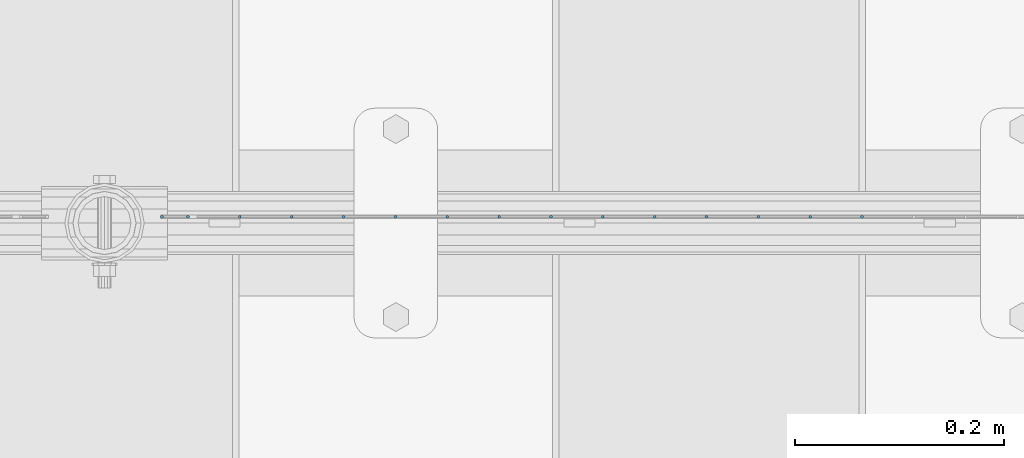
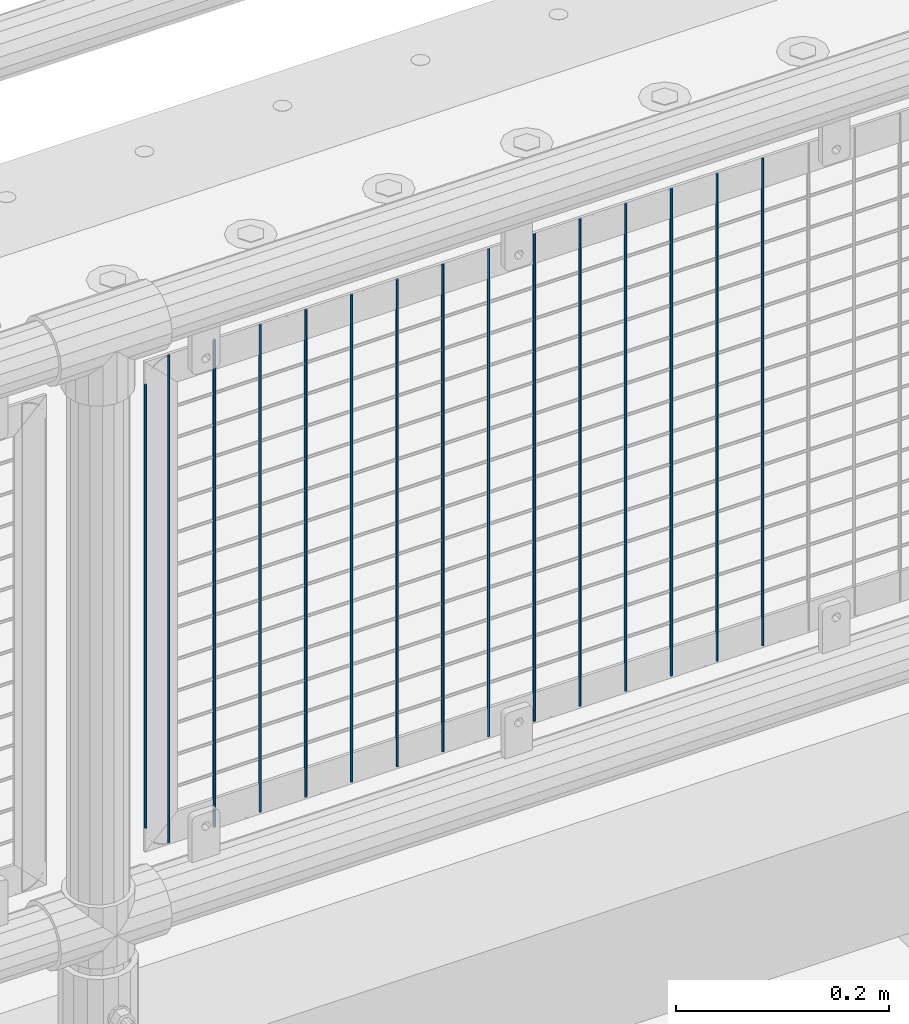
# One storey, part 69 of 257: 15 columns.
"""IFC2X3 building model written with IfcOpenShell, lengths in millimetres."""

import ifcopenshell
import ifcopenshell.guid

model = None  # the IFC model being written
_history = None  # IfcOwnerHistory: only IFC2X3 demands one
_inside = {}  # id of a spatial element -> (the spatial element, [elements in it])
_under = {}  # id of a project, library or spatial element -> (it, [spatial elements below it])
_declared = {}  # id of a project -> (the project, [libraries it declares])
_typed = {}  # id of a type object -> (the type object, [elements of that type])
_made_of = {}  # id of a material, layer set ... -> (it, [elements and type objects made of it])


def new_model(schema):
    """Start an empty IFC model of exactly this schema.

    Asked for "IFC4X3", IfcOpenShell would pick the latest addendum, in which some entities
    have other attributes; the version numbers below select the first issue.
    IFC2X3 requires an IfcOwnerHistory on every rooted entity: one is made here for all.
    """
    global model, _history
    if schema == "IFC4X3":
        model = ifcopenshell.file(schema_version=(4, 3, 0, 0))
    else:
        model = ifcopenshell.file(schema=schema)
    _inside.clear()
    _under.clear()
    _declared.clear()
    _typed.clear()
    _made_of.clear()
    _history = None
    if model.schema == "IFC2X3":
        org = make("IfcOrganization", Name="unknown")
        user = make(
            "IfcPersonAndOrganization",
            ThePerson=make("IfcPerson", FamilyName="unknown"),
            TheOrganization=org,
        )
        app = make(
            "IfcApplication",
            ApplicationDeveloper=org,
            Version="unknown",
            ApplicationFullName="unknown",
            ApplicationIdentifier="unknown",
        )
        _history = make(
            "IfcOwnerHistory",
            OwningUser=user,
            OwningApplication=app,
            ChangeAction="ADDED",
            CreationDate=0,
        )
    return model


def make(cls, **values):
    """One entity of the class cls with the attributes given. An attribute that is None is left unset."""
    return model.create_entity(
        cls, **{name: value for name, value in values.items() if value is not None}
    )


def rooted(cls, **values):
    """An entity with a GlobalId (a new one), such as an element, a storey or a relation."""
    return make(cls, GlobalId=ifcopenshell.guid.new(), OwnerHistory=_history, **values)


def si_unit(unit_type, name, prefix=None):
    """IfcSIUnit, for example si_unit("LENGTHUNIT", "METRE", prefix="MILLI")."""
    return make("IfcSIUnit", UnitType=unit_type, Prefix=prefix, Name=name)


def assignment(units):
    """IfcUnitAssignment: the units of a project."""
    return None if units is None else make("IfcUnitAssignment", Units=units)


def point(xyz):
    """IfcCartesianPoint."""
    return None if xyz is None else make("IfcCartesianPoint", Coordinates=xyz)


def direction(xyz):
    """IfcDirection."""
    return None if xyz is None else make("IfcDirection", DirectionRatios=xyz)


def frame(location, z_axis=None, x_axis=None):
    """IfcAxis2Placement3D, a coordinate frame: its origin and axes. An axis left out is left unset."""
    return make(
        "IfcAxis2Placement3D",
        Location=point(location),
        Axis=direction(z_axis),
        RefDirection=direction(x_axis),
    )


def origin_with_axes():
    """The frame at (0, 0, 0) with the z axis (0, 0, 1) and the x axis (1, 0, 0) written out."""
    return frame((0.0, 0.0, 0.0), z_axis=(0.0, 0.0, 1.0), x_axis=(1.0, 0.0, 0.0))


def place(relative_to, where):
    """IfcLocalPlacement: puts the frame where relative to a parent placement (None: the world)."""
    return make(
        "IfcLocalPlacement", PlacementRelTo=relative_to, RelativePlacement=where
    )


def context(
    kind, dimensions, precision=None, world=None, true_north=None, identifier=None
):
    """IfcGeometricRepresentationContext, for example the 3D "Model" context."""
    return make(
        "IfcGeometricRepresentationContext",
        ContextIdentifier=identifier,
        ContextType=kind,
        CoordinateSpaceDimension=dimensions,
        Precision=precision,
        WorldCoordinateSystem=world,
        TrueNorth=true_north,
    )


def subcontext(parent, identifier, kind, view, scale=None):
    """IfcGeometricRepresentationSubContext, for example "Body" below "Model"."""
    return make(
        "IfcGeometricRepresentationSubContext",
        ContextIdentifier=identifier,
        ContextType=kind,
        ParentContext=parent,
        TargetScale=scale,
        TargetView=view,
    )


def project(units=None, contexts=None):
    """IfcProject with its units and contexts."""
    return rooted(
        "IfcProject",
        Name="project",
        RepresentationContexts=contexts,
        UnitsInContext=assignment(units),
    )


def spatial(cls, under=None, at=None, **own):
    """A site, building, storey or space (cls), placed at a placement, below another one or the project."""
    s = rooted(cls, ObjectPlacement=at, **own)
    if under is not None:
        _under.setdefault(under.id(), (under, []))[1].append(s)
    return s


def faces_of(points, faces, orient=None, outer=None):
    """IfcFace entities. A face is a list of loops; a loop is a list of indices into points, from 0.

    orient and outer hold one flag for each loop. By default every Orientation is true, the
    first loop of a face is its IfcFaceOuterBound and the others are IfcFaceBound.
    """
    made = []
    for i, loops in enumerate(faces):
        bounds = []
        for j, loop in enumerate(loops):
            is_outer = j == 0 if outer is None else outer[i][j]
            bounds.append(
                make(
                    "IfcFaceOuterBound" if is_outer else "IfcFaceBound",
                    Bound=make("IfcPolyLoop", Polygon=[points[k] for k in loop]),
                    Orientation=True if orient is None else orient[i][j],
                )
            )
        made.append(make("IfcFace", Bounds=bounds))
    return made


def faceted_brep(points, faces, orient=None, outer=None, voids=None):
    """IfcFacetedBrep: a solid bounded by flat faces; with voids (closed shells), ...WithVoids."""
    shared = [point(p) for p in points]
    hull = make("IfcClosedShell", CfsFaces=faces_of(shared, faces, orient, outer))
    if voids is None:
        return make("IfcFacetedBrep", Outer=hull)
    return make(
        "IfcFacetedBrepWithVoids",
        Outer=hull,
        Voids=[
            make(cls, CfsFaces=faces_of(shared, fs, o, b)) for cls, fs, o, b in voids
        ],
    )


def shape(context_of_items, identifier, shape_type, items):
    """IfcShapeRepresentation: the items that make up one representation, for example the "Body"."""
    return make(
        "IfcShapeRepresentation",
        ContextOfItems=context_of_items,
        RepresentationIdentifier=identifier,
        RepresentationType=shape_type,
        Items=items,
    )


def material(Name=None, Category=None):
    """IfcMaterial."""
    return make("IfcMaterial", Name=Name, Category=Category)


def made_of(thing, what):
    """Note that an element or type object is made of a material, layer set ...; save() writes the relation."""
    if what is not None:
        _made_of.setdefault(what.id(), (what, []))[1].append(thing)
    return thing


def type_object(cls, material=None, **own):
    """A type object (cls), such as IfcWallType, which elements share."""
    return made_of(rooted(cls, **own), material)


def element(
    cls,
    number,
    at=None,
    inside=None,
    cuts=None,
    type_object=None,
    material=None,
    context=None,
    identifier="Body",
    shape_type=None,
    held_by="IfcProductDefinitionShape",
    body=None,
    shapes=None,
    **own,
):
    """One element of the class cls, such as IfcWall. Its Tag is "e" and its number.

    at: its placement. inside: the storey or other place that contains it. cuts: it is an
    opening in that element (IfcRelVoidsElement). A single representation is given by context,
    identifier, shape_type and body (its items); several are given by shapes. held_by: the class
    of the entity that holds the representations. save() writes the other relations.
    """
    e = rooted(cls, Tag="e%d" % number, ObjectPlacement=at, **own)
    if body is not None:
        shapes = [shape(context, identifier, shape_type, body)]
    if shapes is not None:
        e.Representation = make(held_by, Representations=shapes)
    if inside is not None:
        _inside.setdefault(inside.id(), (inside, []))[1].append(e)
    if cuts is not None:
        rooted(
            "IfcRelVoidsElement", RelatingBuildingElement=cuts, RelatedOpeningElement=e
        )
    if type_object is not None:
        _typed.setdefault(type_object.id(), (type_object, []))[1].append(e)
    return made_of(e, material)


def aggregate(whole, parts):
    """IfcRelAggregates: a whole, such as a stair, and the parts it consists of."""
    return rooted("IfcRelAggregates", RelatingObject=whole, RelatedObjects=parts)


def save(model, path):
    """Write the relations noted so far, then the file.

    IfcRelAggregates (storeys below a building ...), IfcRelContainedInSpatialStructure (elements
    in a storey), IfcRelDefinesByType, IfcRelAssociatesMaterial and IfcRelDeclares: one each for
    every whole, place, type object, material and project.
    """
    for whole, parts in _under.values():
        aggregate(whole, parts)
    for where, things in _inside.values():
        rooted(
            "IfcRelContainedInSpatialStructure",
            RelatedElements=things,
            RelatingStructure=where,
        )
    for kind, things in _typed.values():
        rooted("IfcRelDefinesByType", RelatedObjects=things, RelatingType=kind)
    for what, things in _made_of.values():
        rooted("IfcRelAssociatesMaterial", RelatedObjects=things, RelatingMaterial=what)
    for by, libraries in _declared.values():
        rooted("IfcRelDeclares", RelatingContext=by, RelatedDefinitions=libraries)
    model.write(path)


model = new_model("IFC2X3")

# Units and contexts
model_context = context("Model", 3, precision=1e-05, world=origin_with_axes())
body_context = subcontext(model_context, "Body", "Model", "MODEL_VIEW")
ifc_project = project(units=[si_unit("LENGTHUNIT", "METRE", prefix="MILLI"), si_unit("AREAUNIT", "SQUARE_METRE"), si_unit("VOLUMEUNIT", "CUBIC_METRE"), si_unit("MASSUNIT", "GRAM", prefix="KILO"), si_unit("TIMEUNIT", "SECOND"), si_unit("PLANEANGLEUNIT", "RADIAN"), si_unit("SOLIDANGLEUNIT", "STERADIAN"), si_unit("THERMODYNAMICTEMPERATUREUNIT", "DEGREE_CELSIUS"), si_unit("LUMINOUSINTENSITYUNIT", "LUMEN")], contexts=[model_context])

# Site, building, storey
site_placement = place(None, origin_with_axes())
site = spatial("IfcSite", under=ifc_project, at=site_placement, CompositionType="ELEMENT")
building_placement = place(site_placement, origin_with_axes())
building = spatial("IfcBuilding", under=site, at=building_placement, Name="Standard", CompositionType="ELEMENT")
storey_placement = place(building_placement, origin_with_axes())
storey = spatial("IfcBuildingStorey", under=building, at=storey_placement, Name="Undefined", CompositionType="ELEMENT", Elevation=0.0)

# Columns
ifc_material = material(Name="Misc_Undefined")
column_type = type_object("IfcColumnType", Name="D3", PredefinedType="NOTDEFINED")
for number, where, z_axis, x_axis in (
    (1, (45396.515, 10670.5, 353.02), (-1.0, 0.0, 0.0), (0.0, 0.0, 1.0)),
    (2, (45346.86, 10670.5, 353.02), (-1.0, 0.0, 0.0), (0.0, 0.0, 1.0)),
    (3, (45297.205, 10670.5, 353.02), (-1.0, 0.0, 0.0), (0.0, 0.0, 1.0)),
    (4, (45247.55, 10670.5, 353.02), (-1.0, 0.0, 0.0), (0.0, 0.0, 1.0)),
    (5, (45197.895, 10670.5, 353.02), (-1.0, 0.0, 0.0), (0.0, 0.0, 1.0)),
    (6, (45148.24, 10670.5, 353.02), (-1.0, 0.0, 0.0), (0.0, 0.0, 1.0)),
    (7, (45098.585, 10670.5, 353.02), (-1.0, 0.0, 0.0), (0.0, 0.0, 1.0)),
    (8, (45048.93, 10670.5, 353.02), (-1.0, 0.0, 0.0), (0.0, 0.0, 1.0)),
    (9, (44999.275, 10670.5, 353.02), (-1.0, 0.0, 0.0), (0.0, 0.0, 1.0)),
    (10, (44949.62, 10670.5, 353.02), (-1.0, 0.0, 0.0), (0.0, 0.0, 1.0)),
    (11, (44899.965, 10670.5, 353.02), (-1.0, 0.0, 0.0), (0.0, 0.0, 1.0)),
    (12, (44850.3103448276, 10670.5, 353.02), (-1.0, 0.0, 0.0), (0.0, 0.0, 1.0)),
    (13, (44800.6551724138, 10670.5, 353.02), (-0.999999999962839, 0.0, 8.62099999968473e-06), (8.62099999949798e-06, 0.0, 0.999999999962839)),
):
    element("IfcColumn", number, at=place(storey_placement, frame(where, z_axis=z_axis, x_axis=x_axis)), inside=storey, type_object=column_type, material=ifc_material, ObjectType="D3", context=body_context, shape_type="Brep", body=[
        faceted_brep([(0.0, -1.5, -5.6843418860808e-14), (0.0, -0.750000000001819, -1.29903810567669), (560.0, -0.75, -1.29903810567339), (560.0, -1.5, 0.0), (7.27595761418343e-12, 0.749999999998181, -1.29903810567669), (560.0, 0.75, -1.29903810567339), (0.0, 1.5, -5.6843418860808e-14), (560.0, 1.5, 0.0), (7.27595761418343e-12, 0.749999999998181, 1.29903810567669), (560.0, 0.75, 1.29903810567339), (0.0, -0.750000000001819, 1.29903810567669), (560.0, -0.75, 1.29903810567339)], [[[0, 1, 2, 3]], [[1, 4, 5, 2]], [[4, 6, 7, 5]], [[6, 8, 9, 7]], [[8, 10, 11, 9]], [[10, 0, 3, 11]], [[5, 7, 9, 11, 3, 2]], [[10, 8, 6, 4, 1, 0]]]),
    ])
column_1_placement = place(storey_placement, frame((44726.0, 10670.5, 378.02), z_axis=(-1.0, 0.0, 0.0), x_axis=(0.0, 0.0, 1.0)))
element("IfcColumn", 14, at=column_1_placement, inside=storey, type_object=column_type, material=ifc_material, ObjectType="D3", context=body_context, shape_type="Brep", body=[
    faceted_brep([(0.0, -1.5, -5.6843418860808e-14), (0.0, -0.750000000001819, -1.29903810567669), (510.0, -0.75, -1.29903810567339), (510.0, -1.5, 0.0), (7.27595761418343e-12, 0.749999999998181, -1.29903810567669), (510.0, 0.75, -1.29903810567339), (0.0, 1.5, -5.6843418860808e-14), (510.0, 1.5, 0.0), (7.27595761418343e-12, 0.749999999998181, 1.29903810567669), (510.0, 0.75, 1.29903810567339), (0.0, -0.750000000001819, 1.29903810567669), (510.0, -0.75, 1.29903810567339)], [[[0, 1, 2, 3]], [[1, 4, 5, 2]], [[4, 6, 7, 5]], [[6, 8, 9, 7]], [[8, 10, 11, 9]], [[10, 0, 3, 11]], [[5, 7, 9, 11, 3, 2]], [[10, 8, 6, 4, 1, 0]]]),
])
column_2_placement = place(storey_placement, frame((44751.0, 10670.5, 353.02), z_axis=(-1.0, 0.0, 0.0), x_axis=(0.0, 0.0, 1.0)))
element("IfcColumn", 15, at=column_2_placement, inside=storey, type_object=column_type, material=ifc_material, ObjectType="D3", context=body_context, shape_type="Brep", body=[
    faceted_brep([(0.0, -1.5, -5.6843418860808e-14), (0.0, -0.750000000001819, -1.29903810567669), (560.0, -0.75, -1.29903810567339), (560.0, -1.5, 0.0), (7.27595761418343e-12, 0.749999999998181, -1.29903810567669), (560.0, 0.75, -1.29903810567339), (0.0, 1.5, -5.6843418860808e-14), (560.0, 1.5, 0.0), (7.27595761418343e-12, 0.749999999998181, 1.29903810567669), (560.0, 0.75, 1.29903810567339), (0.0, -0.750000000001819, 1.29903810567669), (560.0, -0.75, 1.29903810567339)], [[[0, 1, 2, 3]], [[1, 4, 5, 2]], [[4, 6, 7, 5]], [[6, 8, 9, 7]], [[8, 10, 11, 9]], [[10, 0, 3, 11]], [[5, 7, 9, 11, 3, 2]], [[10, 8, 6, 4, 1, 0]]]),
])

save(model, "model.ifc")
